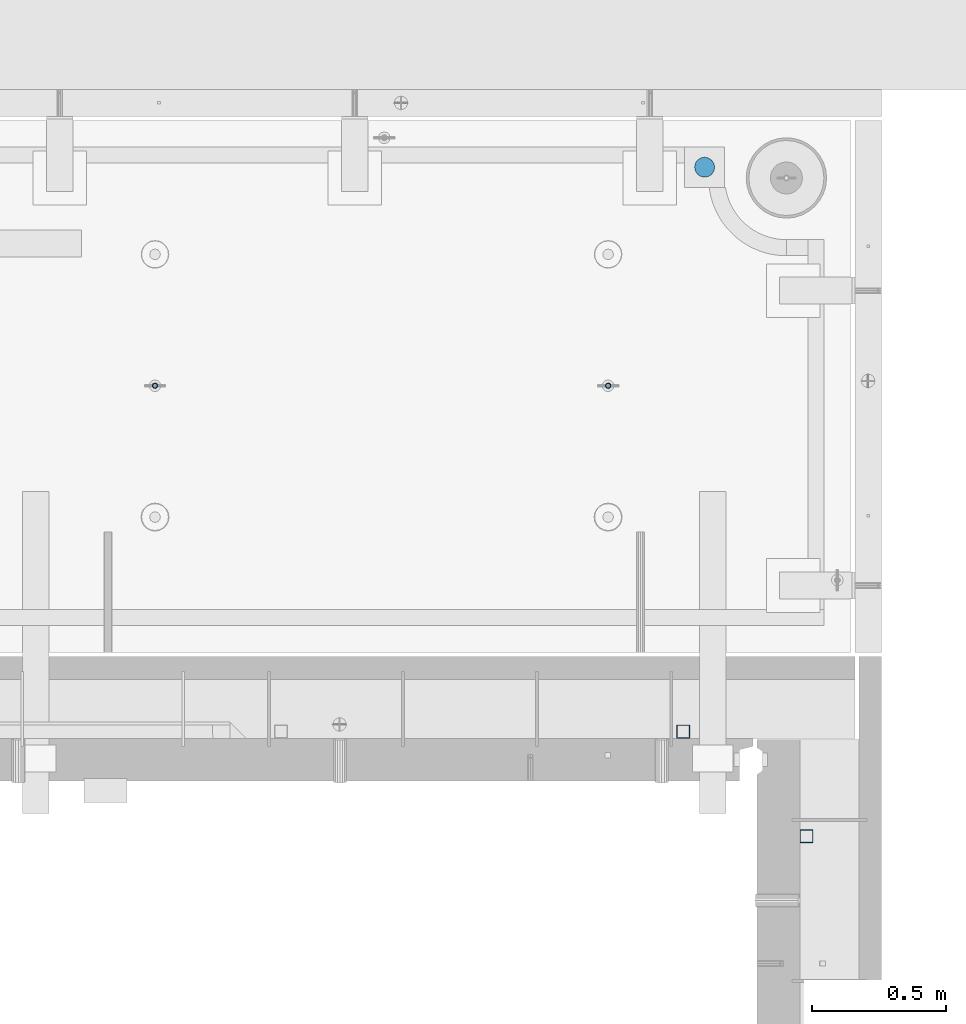
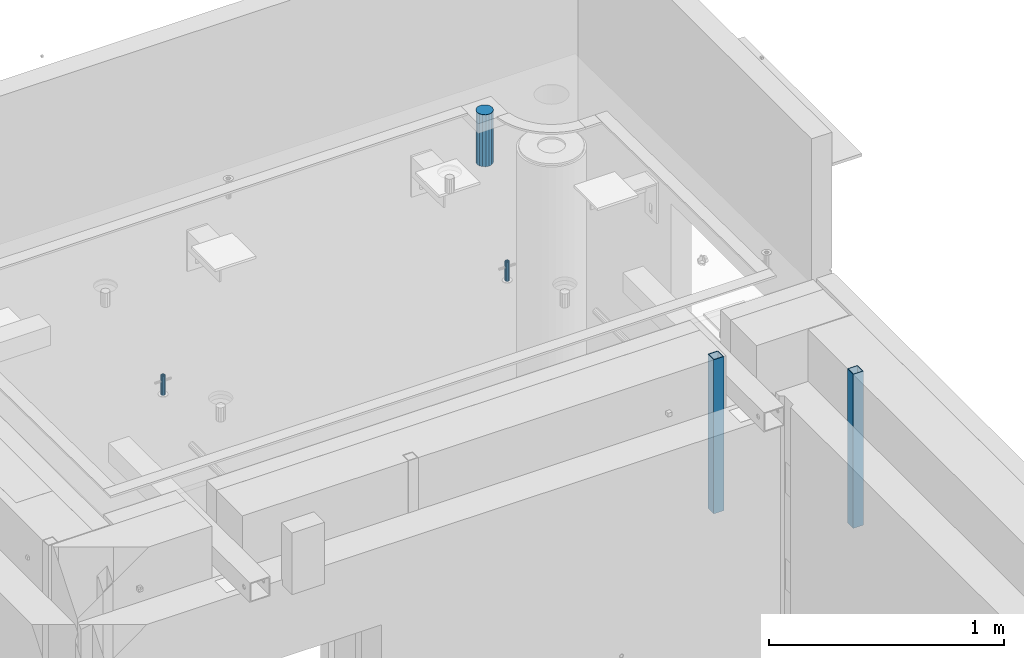
# One storey, part 22 of 264: 5 columns, 7 elements without a shape of their own.
"""IFC2X3 building model written with IfcOpenShell, lengths in millimetres."""

from ifc_helpers import new_model, si_unit, frame, origin_with_axes, place, context, subcontext, project, spatial, faceted_brep, material, type_object, element, aggregate, save


model = new_model("IFC2X3")

# Units and contexts
model_context = context("Model", 3, precision=1e-05, world=origin_with_axes())
body_context = subcontext(model_context, "Body", "Model", "MODEL_VIEW")
ifc_project = project(units=[si_unit("LENGTHUNIT", "METRE", prefix="MILLI"), si_unit("AREAUNIT", "SQUARE_METRE"), si_unit("VOLUMEUNIT", "CUBIC_METRE"), si_unit("MASSUNIT", "GRAM", prefix="KILO"), si_unit("TIMEUNIT", "SECOND"), si_unit("PLANEANGLEUNIT", "RADIAN"), si_unit("SOLIDANGLEUNIT", "STERADIAN"), si_unit("THERMODYNAMICTEMPERATUREUNIT", "DEGREE_CELSIUS"), si_unit("LUMINOUSINTENSITYUNIT", "LUMEN")], contexts=[model_context])

# Site, building, storey
site_placement = place(None, origin_with_axes())
site = spatial("IfcSite", under=ifc_project, at=site_placement, CompositionType="ELEMENT")
building_placement = place(site_placement, origin_with_axes())
building = spatial("IfcBuilding", under=site, at=building_placement, CompositionType="ELEMENT")
storey_placement = place(building_placement, origin_with_axes())
storey = spatial("IfcBuildingStorey", under=building, at=storey_placement, Name="K", CompositionType="ELEMENT", Elevation=0.0)

# Assemblies, column
assembly_1_placement = place(storey_placement, origin_with_axes())
assembly_1 = element("IfcElementAssembly", 1, at=assembly_1_placement, inside=storey, AssemblyPlace="NOTDEFINED", PredefinedType="REINFORCEMENT_UNIT")
assembly_2_placement = place(assembly_1_placement, origin_with_axes())
assembly_2 = element("IfcElementAssembly", 2, at=assembly_2_placement, Name="Steel Assembly", AssemblyPlace="NOTDEFINED", PredefinedType="RIGID_FRAME")
aggregate(assembly_1, [assembly_2])
ifc_material_1 = material(Name="STEEL/S355J2")
column_type_1 = type_object("IfcColumnType", Name="50X50X3", PredefinedType="NOTDEFINED")
column_1_placement = place(assembly_2_placement, frame((34625.0, 20605.0, 80940.0), z_axis=(1.0, 0.0, 0.0), x_axis=(0.0, 0.0, 1.0)))
column_1 = element("IfcColumn", 3, at=column_1_placement, type_object=column_type_1, material=ifc_material_1, ObjectType="50X50X3", context=body_context, shape_type="Brep", body=[
    faceted_brep([(0.0, 22.0, -22.0), (0.0, -22.0, -22.0), (800.0, -22.0, -22.0), (800.0, 22.0, -22.0), (0.0, -22.0, 22.0), (800.0, -22.0, 22.0), (0.0, 22.0, 22.0), (800.0, 22.0, 22.0), (0.0, 25.0, -25.0), (0.0, 25.0, 25.0), (800.0, 25.0, 25.0), (800.0, 25.0, -25.0), (0.0, -25.0, 25.0), (800.0, -25.0, 25.0), (0.0, -25.0, -25.0), (800.0, -25.0, -25.0)], [[[0, 1, 2, 3]], [[1, 4, 5, 2]], [[4, 6, 7, 5]], [[6, 0, 3, 7]], [[8, 9, 10, 11]], [[9, 12, 13, 10]], [[12, 14, 15, 13]], [[14, 8, 11, 15]], [[13, 15, 11, 10], [5, 7, 3, 2]], [[14, 12, 9, 8], [6, 4, 1, 0]]]),
])
aggregate(assembly_2, [column_1])

assembly_3_placement = place(storey_placement, origin_with_axes())
assembly_3 = element("IfcElementAssembly", 4, at=assembly_3_placement, inside=storey, AssemblyPlace="NOTDEFINED", PredefinedType="REINFORCEMENT_UNIT")
assembly_4_placement = place(assembly_3_placement, origin_with_axes())
assembly_4 = element("IfcElementAssembly", 5, at=assembly_4_placement, Name="Steel Assembly", AssemblyPlace="NOTDEFINED", PredefinedType="RIGID_FRAME")
aggregate(assembly_3, [assembly_4])
column_2_placement = place(assembly_4_placement, frame((35085.0, 20215.0002861023, 80940.0), z_axis=(0.0, -1.0, 0.0), x_axis=(0.0, 0.0, 1.0)))
column_2 = element("IfcColumn", 6, at=column_2_placement, type_object=column_type_1, material=ifc_material_1, ObjectType="50X50X3", context=body_context, shape_type="Brep", body=[
    faceted_brep([(0.0, 22.0, -22.0), (0.0, -22.0, -22.0), (800.0, -22.0, -22.0), (800.0, 22.0, -22.0), (0.0, -22.0, 22.0), (800.0, -22.0, 22.0), (0.0, 22.0, 22.0), (800.0, 22.0, 22.0), (0.0, 25.0, -25.0), (0.0, 25.0, 25.0), (800.0, 25.0, 25.0), (800.0, 25.0, -25.0), (0.0, -25.0, 25.0), (800.0, -25.0, 25.0), (0.0, -25.0, -25.0), (800.0, -25.0, -25.0)], [[[0, 1, 2, 3]], [[1, 4, 5, 2]], [[4, 6, 7, 5]], [[6, 0, 3, 7]], [[8, 9, 10, 11]], [[9, 12, 13, 10]], [[12, 14, 15, 13]], [[14, 8, 11, 15]], [[13, 15, 11, 10], [5, 7, 3, 2]], [[14, 12, 9, 8], [6, 4, 1, 0]]]),
])
aggregate(assembly_4, [column_2])

# Assemblies, columns
assembly_5_placement = place(storey_placement, origin_with_axes())
assembly_5 = element("IfcElementAssembly", 7, at=assembly_5_placement, inside=storey, AssemblyPlace="NOTDEFINED", PredefinedType="REINFORCEMENT_UNIT")
assembly_6_placement = place(assembly_5_placement, origin_with_axes())
assembly_6 = element("IfcElementAssembly", 8, at=assembly_6_placement, Name="Steel Assembly", AssemblyPlace="NOTDEFINED", PredefinedType="RIGID_FRAME")
ifc_material_2 = material(Name="STEEL/1.4301")
column_type_2 = type_object("IfcColumnType", PredefinedType="NOTDEFINED")
column_3_placement = place(assembly_6_placement, frame((32654.9901431868, 21895.0034426477, 81445.0), z_axis=(0.000321686000089053, -0.999999948259057, 0.0), x_axis=(0.0, 0.0, 1.0)))
column_3 = element("IfcColumn", 9, at=column_3_placement, type_object=column_type_2, material=ifc_material_2, context=body_context, shape_type="Brep", body=[
    faceted_brep([(0.0, -8.0, 0.0), (0.0, -6.92820323027263, 4.0), (100.000000000029, -6.92820323027263, 4.0), (100.000000000029, -7.99999999999636, 0.0), (0.0, -4.0, 6.92820323027627), (100.000000000029, -4.0, 6.92820323027536), (0.0, 0.0, 8.0), (100.000000000029, 3.63797880709171e-12, 8.0), (0.0, 4.0, 6.92820323027627), (100.000000000029, 4.0, 6.92820323027536), (0.0, 6.92820323027263, 4.0), (100.000000000029, 6.92820323027627, 3.99999999999909), (0.0, 8.0, 0.0), (100.000000000029, 8.0, 0.0), (0.0, 6.92820323027263, -4.0), (100.000000000029, 6.92820323027627, -4.00000000000091), (0.0, 4.0, -6.92820323027627), (100.000000000029, 4.00000000000364, -6.92820323027536), (0.0, 0.0, -8.0), (100.000000000029, 3.63797880709171e-12, -8.00000000000091), (0.0, -4.0, -6.92820323027627), (100.000000000029, -3.99999999999636, -6.92820323027627), (0.0, -6.92820323027263, -4.0), (100.000000000029, -6.92820323027263, -4.0), (0.0, -10.4999999999927, -1.45519152283669e-11), (0.0, -9.09326673972828, -5.25000000001455), (100.000000000262, -9.09326673972828, -5.25000000001455), (100.000000000262, -10.4999999999927, -1.45519152283669e-11), (0.0, -5.24999999998545, -9.09326673974283), (100.000000000262, -5.24999999998545, -9.09326673974283), (0.0, 7.27595761418343e-12, -10.5), (100.000000000262, 7.27595761418343e-12, -10.5), (0.0, 5.25000000001455, -9.09326673975738), (100.000000000262, 5.25000000001455, -9.09326673975738), (0.0, 9.09326673975011, -5.25000000001455), (100.000000000262, 9.09326673975011, -5.25000000001455), (0.0, 10.5000000000073, -1.45519152283669e-11), (100.000000000262, 10.5000000000073, -1.45519152283669e-11), (0.0, 9.09326673975011, 5.25), (100.000000000262, 9.09326673975011, 5.25), (0.0, 5.25000000000728, 9.09326673972828), (100.000000000262, 5.25000000000728, 9.09326673972828), (0.0, 1.45519152283669e-11, 10.4999999999854), (100.000000000262, 1.45519152283669e-11, 10.4999999999854), (0.0, -5.24999999999272, 9.09326673972828), (100.000000000262, -5.24999999999272, 9.09326673972828), (0.0, -9.09326673972828, 5.24999999998545), (100.000000000262, -9.09326673972828, 5.24999999998545)], [[[0, 1, 2, 3]], [[1, 4, 5, 2]], [[4, 6, 7, 5]], [[6, 8, 9, 7]], [[8, 10, 11, 9]], [[10, 12, 13, 11]], [[12, 14, 15, 13]], [[14, 16, 17, 15]], [[16, 18, 19, 17]], [[18, 20, 21, 19]], [[20, 22, 23, 21]], [[22, 0, 3, 23]], [[24, 25, 26, 27]], [[25, 28, 29, 26]], [[28, 30, 31, 29]], [[30, 32, 33, 31]], [[32, 34, 35, 33]], [[34, 36, 37, 35]], [[36, 38, 39, 37]], [[38, 40, 41, 39]], [[40, 42, 43, 41]], [[42, 44, 45, 43]], [[44, 46, 47, 45]], [[46, 24, 27, 47]], [[29, 31, 33, 35, 37, 39, 41, 43, 45, 47, 27, 26], [5, 7, 9, 11, 13, 15, 17, 19, 21, 23, 3, 2]], [[46, 44, 42, 40, 38, 36, 34, 32, 30, 28, 25, 24], [22, 20, 18, 16, 14, 12, 10, 8, 6, 4, 1, 0]]]),
])
aggregate(assembly_6, [column_3])
assembly_7_placement = place(assembly_5_placement, origin_with_axes())
assembly_7 = element("IfcElementAssembly", 10, at=assembly_7_placement, Name="Steel Assembly", AssemblyPlace="NOTDEFINED", PredefinedType="RIGID_FRAME")
column_4_placement = place(assembly_7_placement, frame((34345.0001431868, 21895.0034426477, 81445.0), z_axis=(0.000321686000089053, -0.999999948259057, 0.0), x_axis=(0.0, 0.0, 1.0)))
column_4 = element("IfcColumn", 11, at=column_4_placement, type_object=column_type_2, material=ifc_material_2, context=body_context, shape_type="Brep", body=[
    faceted_brep([(0.0, -8.0, 0.0), (0.0, -6.92820323027263, 4.0), (100.000000000029, -6.92820323027263, 4.0), (100.000000000029, -7.99999999999636, 0.0), (0.0, -4.0, 6.92820323027627), (100.000000000029, -4.0, 6.92820323027536), (0.0, 0.0, 8.0), (100.000000000029, 3.63797880709171e-12, 8.0), (0.0, 4.0, 6.92820323027627), (100.000000000029, 4.0, 6.92820323027536), (0.0, 6.92820323027263, 4.0), (100.000000000029, 6.92820323027627, 3.99999999999909), (0.0, 8.0, 0.0), (100.000000000029, 8.0, 0.0), (0.0, 6.92820323027263, -4.0), (100.000000000029, 6.92820323027627, -4.00000000000091), (0.0, 4.0, -6.92820323027627), (100.000000000029, 4.00000000000364, -6.92820323027536), (0.0, 0.0, -8.0), (100.000000000029, 3.63797880709171e-12, -8.00000000000091), (0.0, -4.0, -6.92820323027627), (100.000000000029, -3.99999999999636, -6.92820323027627), (0.0, -6.92820323027263, -4.0), (100.000000000029, -6.92820323027263, -4.0), (0.0, -10.4999999999927, -1.45519152283669e-11), (0.0, -9.09326673972828, -5.25000000001455), (100.000000000262, -9.09326673972828, -5.25000000001455), (100.000000000262, -10.4999999999927, -1.45519152283669e-11), (0.0, -5.24999999998545, -9.09326673974283), (100.000000000262, -5.24999999998545, -9.09326673974283), (0.0, 7.27595761418343e-12, -10.5), (100.000000000262, 7.27595761418343e-12, -10.5), (0.0, 5.25000000001455, -9.09326673975738), (100.000000000262, 5.25000000001455, -9.09326673975738), (0.0, 9.09326673975011, -5.25000000001455), (100.000000000262, 9.09326673975011, -5.25000000001455), (0.0, 10.5000000000073, -1.45519152283669e-11), (100.000000000262, 10.5000000000073, -1.45519152283669e-11), (0.0, 9.09326673975011, 5.25), (100.000000000262, 9.09326673975011, 5.25), (0.0, 5.25000000000728, 9.09326673972828), (100.000000000262, 5.25000000000728, 9.09326673972828), (0.0, 1.45519152283669e-11, 10.4999999999854), (100.000000000262, 1.45519152283669e-11, 10.4999999999854), (0.0, -5.24999999999272, 9.09326673972828), (100.000000000262, -5.24999999999272, 9.09326673972828), (0.0, -9.09326673972828, 5.24999999998545), (100.000000000262, -9.09326673972828, 5.24999999998545)], [[[0, 1, 2, 3]], [[1, 4, 5, 2]], [[4, 6, 7, 5]], [[6, 8, 9, 7]], [[8, 10, 11, 9]], [[10, 12, 13, 11]], [[12, 14, 15, 13]], [[14, 16, 17, 15]], [[16, 18, 19, 17]], [[18, 20, 21, 19]], [[20, 22, 23, 21]], [[22, 0, 3, 23]], [[24, 25, 26, 27]], [[25, 28, 29, 26]], [[28, 30, 31, 29]], [[30, 32, 33, 31]], [[32, 34, 35, 33]], [[34, 36, 37, 35]], [[36, 38, 39, 37]], [[38, 40, 41, 39]], [[40, 42, 43, 41]], [[42, 44, 45, 43]], [[44, 46, 47, 45]], [[46, 24, 27, 47]], [[29, 31, 33, 35, 37, 39, 41, 43, 45, 47, 27, 26], [5, 7, 9, 11, 13, 15, 17, 19, 21, 23, 3, 2]], [[46, 44, 42, 40, 38, 36, 34, 32, 30, 28, 25, 24], [22, 20, 18, 16, 14, 12, 10, 8, 6, 4, 1, 0]]]),
])
aggregate(assembly_7, [column_4])
ifc_material_3 = material()
column_type_3 = type_object("IfcColumnType", Name="D75", PredefinedType="NOTDEFINED")
column_5_placement = place(assembly_5_placement, frame((34705.0001431867, 22710.1748906662, 81440.0), z_axis=(-0.9999999949993, -0.000100007000000845, 0.0), x_axis=(0.0, 0.0, 1.0)))
column_5 = element("IfcColumn", 12, at=column_5_placement, type_object=column_type_3, material=ifc_material_3, ObjectType="D75", context=body_context, shape_type="Brep", body=[
    faceted_brep([(0.0, -37.4999999999991, 1.81898940354586e-12), (0.0, -34.6454824691718, -14.3506287136888), (270.0, -34.6454824691718, -14.3506287136888), (270.0, -37.4999999999991, 1.81898940354586e-12), (0.0, -26.5165042944936, -26.5165042944936), (270.0, -26.5165042944936, -26.5165042944936), (0.0, -14.3506287136906, -34.6454824691718), (270.0, -14.3506287136906, -34.6454824691718), (0.0, 9.09494701772928e-13, -37.4999999999982), (270.0, 9.09494701772928e-13, -37.4999999999982), (0.0, 14.3506287136915, -34.6454824691718), (270.0, 14.3506287136915, -34.6454824691718), (0.0, 26.5165042944973, -26.5165042944927), (270.0, 26.5165042944973, -26.5165042944927), (0.0, 34.6454824691746, -14.3506287136897), (270.0, 34.6454824691746, -14.3506287136897), (0.0, 37.5000000000018, 1.81898940354586e-12), (270.0, 37.5000000000018, 1.81898940354586e-12), (0.0, 34.6454824691755, 14.3506287136925), (270.0, 34.6454824691755, 14.3506287136925), (0.0, 26.5165042944964, 26.5165042944973), (270.0, 26.5165042944964, 26.5165042944973), (0.0, 14.3506287136934, 34.6454824691755), (270.0, 14.3506287136934, 34.6454824691755), (0.0, 1.81898940354586e-12, 37.5000000000027), (270.0, 1.81898940354586e-12, 37.5000000000027), (0.0, -14.3506287136897, 34.6454824691746), (270.0, -14.3506287136897, 34.6454824691746), (0.0, -26.5165042944946, 26.5165042944973), (270.0, -26.5165042944946, 26.5165042944973), (0.0, -34.6454824691718, 14.3506287136925), (270.0, -34.6454824691718, 14.3506287136925)], [[[0, 1, 2, 3]], [[1, 4, 5, 2]], [[4, 6, 7, 5]], [[6, 8, 9, 7]], [[8, 10, 11, 9]], [[10, 12, 13, 11]], [[12, 14, 15, 13]], [[14, 16, 17, 15]], [[16, 18, 19, 17]], [[18, 20, 21, 19]], [[20, 22, 23, 21]], [[22, 24, 25, 23]], [[24, 26, 27, 25]], [[26, 28, 29, 27]], [[28, 30, 31, 29]], [[30, 0, 3, 31]], [[5, 7, 9, 11, 13, 15, 17, 19, 21, 23, 25, 27, 29, 31, 3, 2]], [[30, 28, 26, 24, 22, 20, 18, 16, 14, 12, 10, 8, 6, 4, 1, 0]]]),
])
aggregate(assembly_5, [assembly_6, assembly_7, column_5])

save(model, "model.ifc")
